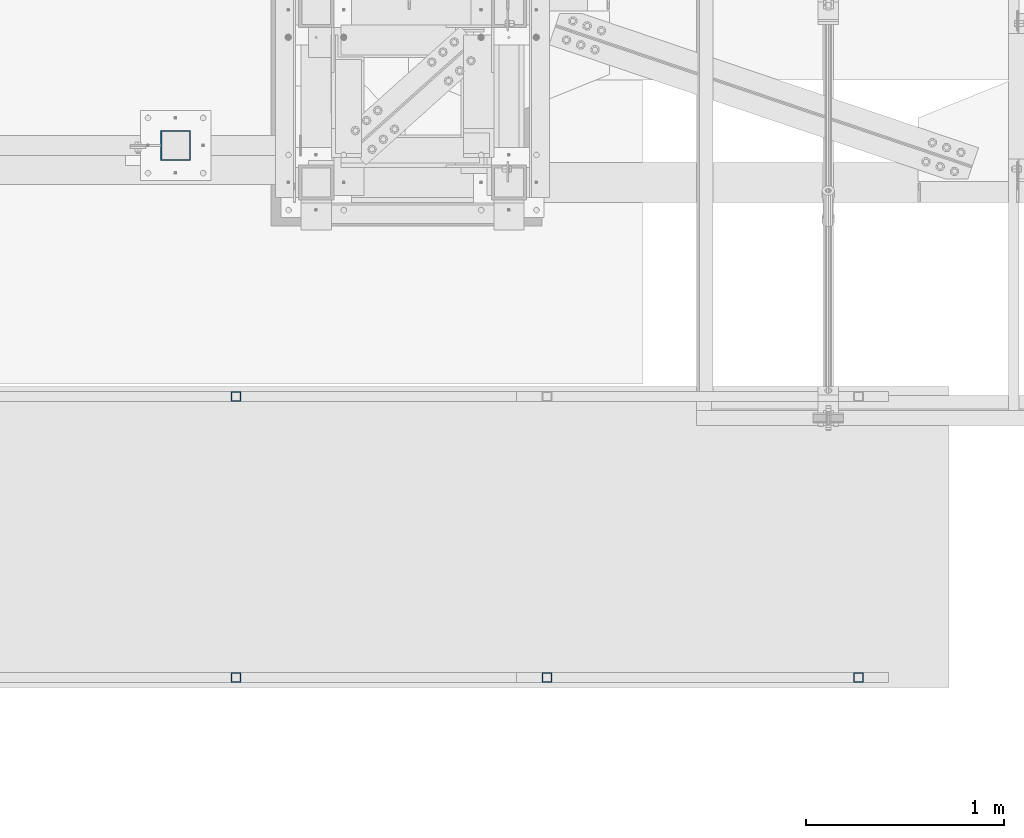
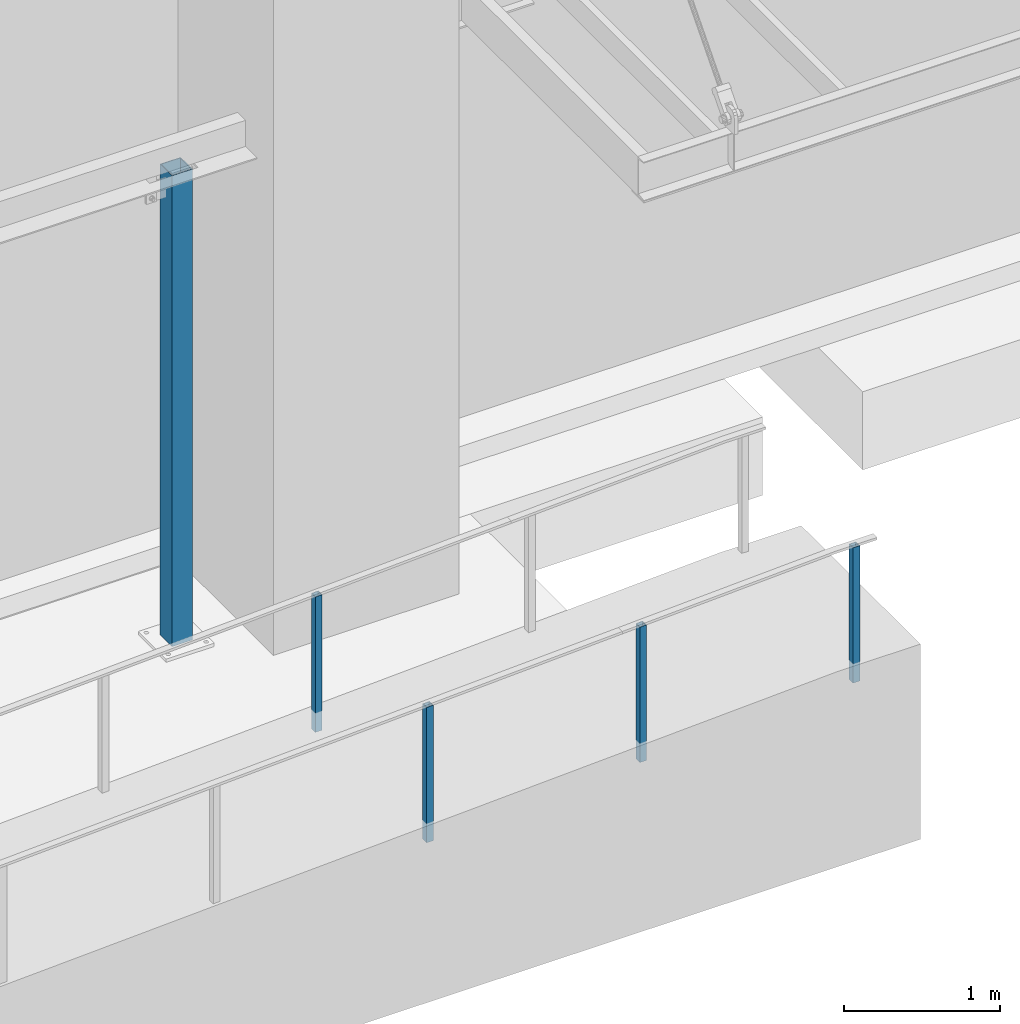
# One storey, part 888 of 1763: 5 columns, 4 elements without a shape of their own.
"""IFC2X3 building model written with IfcOpenShell, lengths in millimetres."""

from ifc_helpers import new_model, si_unit, frame, origin_with_axes, place, context, subcontext, project, spatial, faceted_brep, material, type_object, element, aggregate, save


model = new_model("IFC2X3")

# Units and contexts
model_context = context("Model", 3, precision=1e-05, world=origin_with_axes())
body_context = subcontext(model_context, "Body", "Model", "MODEL_VIEW")
ifc_project = project(units=[si_unit("LENGTHUNIT", "METRE", prefix="MILLI"), si_unit("AREAUNIT", "SQUARE_METRE"), si_unit("VOLUMEUNIT", "CUBIC_METRE"), si_unit("MASSUNIT", "GRAM", prefix="KILO"), si_unit("TIMEUNIT", "SECOND"), si_unit("PLANEANGLEUNIT", "RADIAN"), si_unit("SOLIDANGLEUNIT", "STERADIAN"), si_unit("THERMODYNAMICTEMPERATUREUNIT", "DEGREE_CELSIUS"), si_unit("LUMINOUSINTENSITYUNIT", "LUMEN")], contexts=[model_context])

# Site, building, storey
site_placement = place(None, origin_with_axes())
site = spatial("IfcSite", under=ifc_project, at=site_placement, CompositionType="ELEMENT")
building_placement = place(site_placement, origin_with_axes())
building = spatial("IfcBuilding", under=site, at=building_placement, Name="Undefined", CompositionType="ELEMENT")
storey_placement = place(building_placement, origin_with_axes())
storey = spatial("IfcBuildingStorey", under=building, at=storey_placement, Name="Undefined", CompositionType="ELEMENT", Elevation=0.0)

# Assembly, column
assembly_1_placement = place(storey_placement, origin_with_axes())
assembly_1 = element("IfcElementAssembly", 1, at=assembly_1_placement, inside=storey, Name="HANDRAIL", AssemblyPlace="NOTDEFINED", PredefinedType="RIGID_FRAME")
ifc_material = material()
column_type_1 = type_object("IfcColumnType", Name="2X2X3/16 SQUARE TUBE SS", PredefinedType="NOTDEFINED")
column_1_placement = place(assembly_1_placement, frame((-64591.6999876652, -16535.4002326199, 5038.50789556015), z_axis=(-0.999999999891248, 0.0, 1.47479999968709e-05), x_axis=(1.47479999970212e-05, 0.0, 0.999999999891248)))
column_1 = element("IfcColumn", 2, at=column_1_placement, type_object=column_type_1, material=ifc_material, Name="POST TUBE", ObjectType="2X2X3/16 SQUARE TUBE SS", context=body_context, shape_type="Brep", body=[
    faceted_brep([(0.0, 20.6375000000007, -20.6374999999971), (0.0, -20.6375000000007, -20.6374999999971), (1058.23349084755, -20.6375000000007, -20.6375000024054), (1058.23349084755, 20.6375000000007, -20.6375000024054), (0.0, -20.6375000000007, 20.6374999999971), (1056.26220687483, -20.6375000000007, 20.6374999975815), (0.0, 20.6375000000007, 20.6374999999971), (1056.26220687483, 20.6375000000007, 20.6374999975815), (-1.45519152283669e-11, 25.4000000000015, -25.3999999999869), (1.45519152283669e-11, 25.4000000000015, 25.3999999999796), (1056.03475103182, 25.4000000000015, 25.3999999975786), (1058.46094669056, 25.4000000000015, -25.4000000024098), (0.0, -25.4000000000015, 25.3999999999942), (1056.03475103182, -25.4000000000015, 25.3999999975786), (-1.45519152283669e-11, -25.4000000000015, -25.3999999999869), (1058.46094669056, -25.4000000000015, -25.4000000024098)], [[[0, 1, 2, 3]], [[1, 4, 5, 2]], [[4, 6, 7, 5]], [[6, 0, 3, 7]], [[8, 9, 10, 11]], [[9, 12, 13, 10]], [[12, 14, 15, 13]], [[14, 8, 11, 15]], [[13, 15, 11, 10], [5, 7, 3, 2]], [[14, 12, 9, 8], [6, 4, 1, 0]]]),
])
aggregate(assembly_1, [column_1])

assembly_2_placement = place(storey_placement, origin_with_axes())
assembly_2 = element("IfcElementAssembly", 3, at=assembly_2_placement, inside=storey, Name="HANDRAIL", AssemblyPlace="NOTDEFINED", PredefinedType="RIGID_FRAME")
column_2_placement = place(assembly_2_placement, frame((-63016.9000936682, -17957.80011631, 5113.69667938172), z_axis=(-0.999999999891248, 0.0, 1.47479999968709e-05), x_axis=(1.47479999970212e-05, 0.0, 0.999999999891248)))
column_2 = element("IfcColumn", 4, at=column_2_placement, type_object=column_type_1, material=ifc_material, Name="POST TUBE", ObjectType="2X2X3/16 SQUARE TUBE SS", context=body_context, shape_type="Brep", body=[
    faceted_brep([(0.0, 20.6375000000007, -20.6374999999971), (0.0, -20.6375000000007, -20.6374999999971), (1058.23349084755, -20.6375000000007, -20.6375000024054), (1058.23349084755, 20.6375000000007, -20.6375000024054), (0.0, -20.6375000000007, 20.6374999999971), (1056.26220687483, -20.6375000000007, 20.6374999975815), (0.0, 20.6375000000007, 20.6374999999971), (1056.26220687483, 20.6375000000007, 20.6374999975815), (-1.45519152283669e-11, 25.4000000000015, -25.3999999999869), (1.45519152283669e-11, 25.4000000000015, 25.3999999999796), (1056.03475103182, 25.4000000000015, 25.3999999975786), (1058.46094669056, 25.4000000000015, -25.4000000024098), (0.0, -25.4000000000015, 25.3999999999942), (1056.03475103182, -25.4000000000015, 25.3999999975786), (-1.45519152283669e-11, -25.4000000000015, -25.3999999999869), (1058.46094669056, -25.4000000000015, -25.4000000024098)], [[[0, 1, 2, 3]], [[1, 4, 5, 2]], [[4, 6, 7, 5]], [[6, 0, 3, 7]], [[8, 9, 10, 11]], [[9, 12, 13, 10]], [[12, 14, 15, 13]], [[14, 8, 11, 15]], [[13, 15, 11, 10], [5, 7, 3, 2]], [[14, 12, 9, 8], [6, 4, 1, 0]]]),
])

assembly_3_placement = place(storey_placement, origin_with_axes())
assembly_3 = element("IfcElementAssembly", 5, at=assembly_3_placement, inside=storey, Name="HANDRAIL", AssemblyPlace="NOTDEFINED", PredefinedType="RIGID_FRAME")
column_3_placement = place(assembly_3_placement, frame((-64591.6999876652, -17957.80011631, 5038.50789556015), z_axis=(-0.999999999891248, 0.0, 1.47479999968709e-05), x_axis=(1.47479999970212e-05, 0.0, 0.999999999891248)))
column_3 = element("IfcColumn", 6, at=column_3_placement, type_object=column_type_1, material=ifc_material, Name="POST TUBE", ObjectType="2X2X3/16 SQUARE TUBE SS", context=body_context, shape_type="Brep", body=[
    faceted_brep([(0.0, 20.6375000000007, -20.6374999999971), (0.0, -20.6375000000007, -20.6374999999971), (1058.23349084755, -20.6375000000007, -20.6375000024054), (1058.23349084755, 20.6375000000007, -20.6375000024054), (0.0, -20.6375000000007, 20.6374999999971), (1056.26220687483, -20.6375000000007, 20.6374999975815), (0.0, 20.6375000000007, 20.6374999999971), (1056.26220687483, 20.6375000000007, 20.6374999975815), (-1.45519152283669e-11, 25.4000000000015, -25.3999999999869), (1.45519152283669e-11, 25.4000000000015, 25.3999999999796), (1056.03475103182, 25.4000000000015, 25.3999999975786), (1058.46094669056, 25.4000000000015, -25.4000000024098), (0.0, -25.4000000000015, 25.3999999999942), (1056.03475103182, -25.4000000000015, 25.3999999975786), (-1.45519152283669e-11, -25.4000000000015, -25.3999999999869), (1058.46094669056, -25.4000000000015, -25.4000000024098)], [[[0, 1, 2, 3]], [[1, 4, 5, 2]], [[4, 6, 7, 5]], [[6, 0, 3, 7]], [[8, 9, 10, 11]], [[9, 12, 13, 10]], [[12, 14, 15, 13]], [[14, 8, 11, 15]], [[13, 15, 11, 10], [5, 7, 3, 2]], [[14, 12, 9, 8], [6, 4, 1, 0]]]),
])
aggregate(assembly_3, [column_3])

# Column
column_4_placement = place(assembly_2_placement, frame((-61442.0231239422, -17957.80011631, 5181.60498829066), z_axis=(-0.999999999891248, 0.0, 1.47479999968709e-05), x_axis=(1.47479999970212e-05, 0.0, 0.999999999891248)))
column_4 = element("IfcColumn", 7, at=column_4_placement, type_object=column_type_1, material=ifc_material, Name="POST TUBE", ObjectType="2X2X3/16 SQUARE TUBE SS", context=body_context, shape_type="Brep", body=[
    faceted_brep([(0.0, 20.6375000000007, -20.6374999999971), (0.0, -20.6375000000007, -20.6374999999971), (1057.27454565037, -20.6375000000007, -20.6375000024054), (1057.27454565037, 20.6375000000007, -20.6375000024054), (0.0, -20.6375000000007, 20.6374999999971), (1057.27361877886, -20.6375000000007, 20.6374999975815), (0.0, 20.6375000000007, 20.6374999999971), (1057.27361877886, 20.6375000000007, 20.6374999975815), (-1.45519152283669e-11, 25.4000000000015, -25.3999999999869), (1.45519152283669e-11, 25.4000000000015, 25.3999999999796), (1057.27351183214, 25.4000000000015, 25.3999999975786), (1057.27465259708, 25.4000000000015, -25.4000000024025), (0.0, -25.4000000000015, 25.3999999999942), (1057.27351183214, -25.4000000000015, 25.3999999975786), (-1.45519152283669e-11, -25.4000000000015, -25.3999999999869), (1057.27465259708, -25.4000000000015, -25.4000000024025)], [[[0, 1, 2, 3]], [[1, 4, 5, 2]], [[4, 6, 7, 5]], [[6, 0, 3, 7]], [[8, 9, 10, 11]], [[9, 12, 13, 10]], [[12, 14, 15, 13]], [[14, 8, 11, 15]], [[13, 15, 11, 10], [5, 7, 3, 2]], [[14, 12, 9, 8], [6, 4, 1, 0]]]),
])

aggregate(assembly_2, [column_2, column_4])

# Assembly, column
assembly_4_placement = place(storey_placement, origin_with_axes())
assembly_4 = element("IfcElementAssembly", 8, at=assembly_4_placement, inside=storey, Name="COLUMN", AssemblyPlace="NOTDEFINED", PredefinedType="RIGID_FRAME")
column_type_2 = type_object("IfcColumnType", Name="HSS6X6X1/4", PredefinedType="NOTDEFINED")
column_5_placement = place(assembly_4_placement, frame((-64896.438056465, -15265.4000613784, 5029.2), z_axis=(0.0, 1.0, 0.0), x_axis=(0.0, 0.0, 1.0)))
column_5 = element("IfcColumn", 9, at=column_5_placement, type_object=column_type_2, material=ifc_material, Name="COLUMN", ObjectType="HSS6X6X1/4", context=body_context, shape_type="Brep", body=[
    faceted_brep([(63.4999999999973, 69.8499999999985, -69.8500000000004), (63.4999999999973, -69.8499999999985, -69.8500000000004), (3740.15, -69.8499999999985, -69.8500000000004), (3740.15, 69.8499999999985, -69.8500000000004), (63.4999999999973, -69.8499999999985, 69.8500000000004), (3740.15, -69.8499999999985, 69.8500000000004), (63.4999999999973, 69.8499999999985, 69.8500000000004), (3740.15, 69.8499999999985, 69.8500000000004), (63.4999999999973, 76.1999999999971, -76.2000000000007), (63.4999999999973, 76.1999999999971, 76.2000000000007), (3740.15, 76.1999999999971, 76.2000000000007), (3740.15, 76.1999999999971, -76.2000000000007), (63.4999999999973, -76.1999999999971, 76.2000000000007), (3740.15, -76.1999999999971, 76.2000000000007), (63.4999999999973, -76.1999999999971, -76.2000000000007), (3740.15, -76.1999999999971, -76.2000000000007)], [[[0, 1, 2, 3]], [[1, 4, 5, 2]], [[4, 6, 7, 5]], [[6, 0, 3, 7]], [[8, 9, 10, 11]], [[9, 12, 13, 10]], [[12, 14, 15, 13]], [[14, 8, 11, 15]], [[13, 15, 11, 10], [5, 7, 3, 2]], [[14, 12, 9, 8], [6, 4, 1, 0]]]),
])
aggregate(assembly_4, [column_5])

save(model, "model.ifc")
